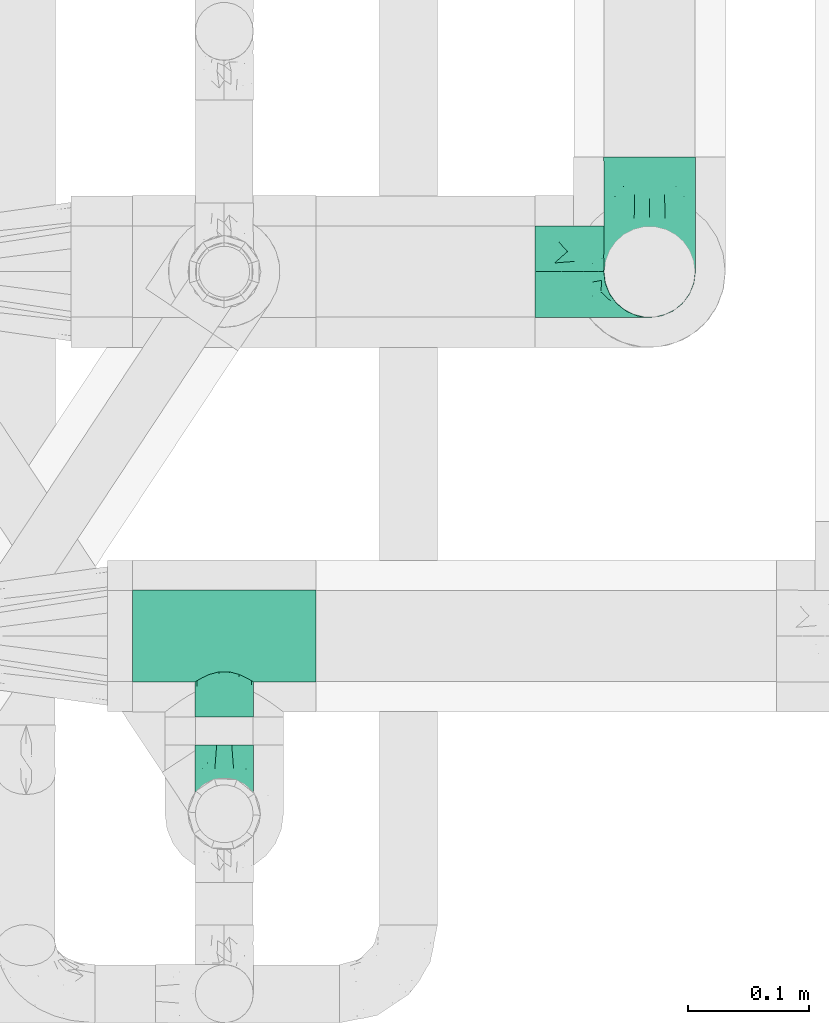
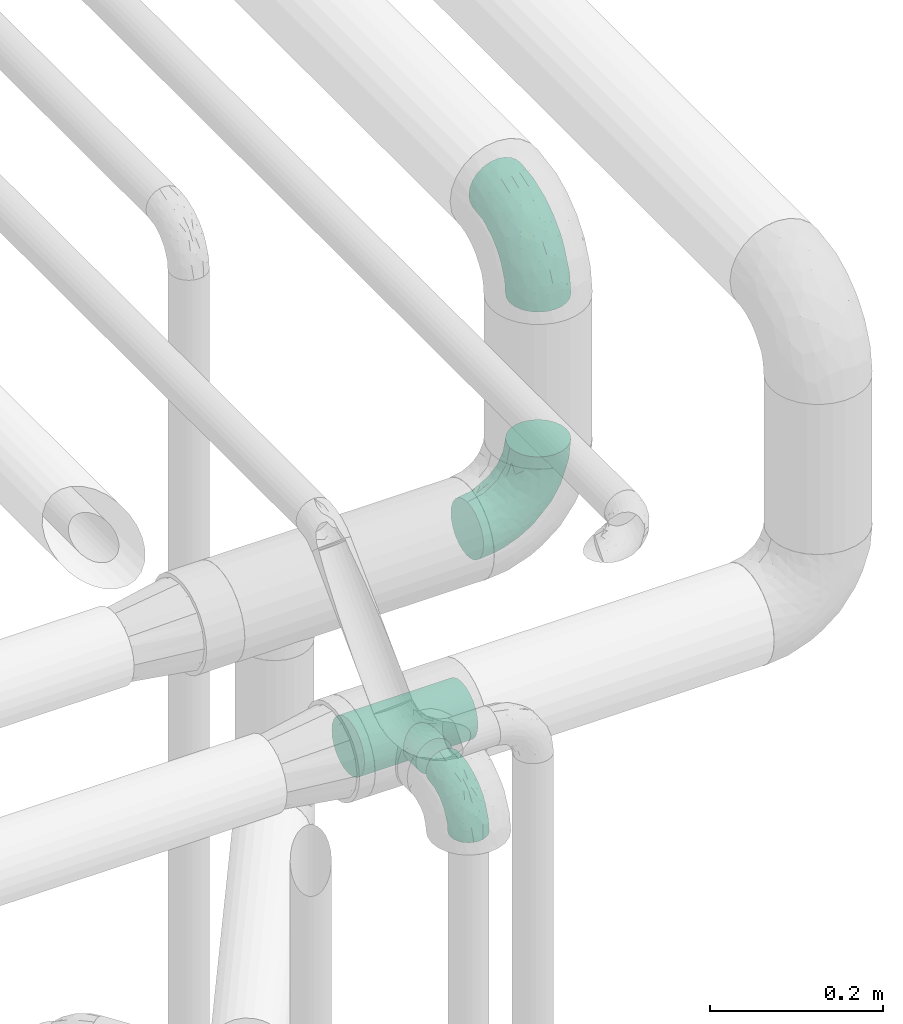
# One storey, part 664 of 827: 4 flow fittings.
"""IFC2X3 building model written with IfcOpenShell, lengths in millimetres."""

from ifc_helpers import new_model, entity, si_unit, converted_unit, derived_unit, direction, frame, origin, place, context, subcontext, project, spatial, faceted_brep, source, transform, mapped, material, type_object, type_shapes, element, save


model = new_model("IFC2X3")

# Units and contexts
model_context = context("Model", 3, precision=0.01, world=origin(), true_north=direction((6.12303176911189e-17, 1.0)))
body_context = subcontext(model_context, "Body", "Model", "MODEL_VIEW")
ifc_project = project(units=[si_unit("LENGTHUNIT", "METRE", prefix="MILLI"), si_unit("AREAUNIT", "SQUARE_METRE"), si_unit("VOLUMEUNIT", "CUBIC_METRE"), converted_unit("PLANEANGLEUNIT", "DEGREE", entity("IfcRatioMeasure", 0.0174532925199433), si_unit("PLANEANGLEUNIT", "RADIAN"), dimensions=[0, 0, 0, 0, 0, 0, 0]), si_unit("MASSUNIT", "GRAM", prefix="KILO"), derived_unit("MASSDENSITYUNIT", [(si_unit("MASSUNIT", "GRAM", prefix="KILO"), 1), (si_unit("LENGTHUNIT", "METRE"), -3)]), derived_unit("MOMENTOFINERTIAUNIT", [(si_unit("LENGTHUNIT", "METRE"), 4)]), si_unit("TIMEUNIT", "SECOND"), si_unit("FREQUENCYUNIT", "HERTZ"), si_unit("THERMODYNAMICTEMPERATUREUNIT", "DEGREE_CELSIUS"), derived_unit("THERMALTRANSMITTANCEUNIT", [(si_unit("MASSUNIT", "GRAM", prefix="KILO"), 1), (si_unit("THERMODYNAMICTEMPERATUREUNIT", "KELVIN"), -1), (si_unit("TIMEUNIT", "SECOND"), -3)]), derived_unit("VOLUMETRICFLOWRATEUNIT", [(si_unit("LENGTHUNIT", "METRE"), 3), (si_unit("TIMEUNIT", "SECOND"), -1)]), derived_unit("MASSFLOWRATEUNIT", [(si_unit("MASSUNIT", "GRAM", prefix="KILO"), 1), (si_unit("TIMEUNIT", "SECOND"), -1)]), derived_unit("ROTATIONALFREQUENCYUNIT", [(si_unit("TIMEUNIT", "SECOND"), -1)]), si_unit("ELECTRICCURRENTUNIT", "AMPERE"), si_unit("ELECTRICVOLTAGEUNIT", "VOLT"), si_unit("POWERUNIT", "WATT"), si_unit("FORCEUNIT", "NEWTON", prefix="KILO"), si_unit("ILLUMINANCEUNIT", "LUX"), si_unit("LUMINOUSFLUXUNIT", "LUMEN"), si_unit("LUMINOUSINTENSITYUNIT", "CANDELA"), derived_unit("USERDEFINED", [(si_unit("MASSUNIT", "GRAM", prefix="KILO"), -1), (si_unit("LENGTHUNIT", "METRE"), -2), (si_unit("TIMEUNIT", "SECOND"), 3), (si_unit("LUMINOUSFLUXUNIT", "LUMEN"), 1)]), derived_unit("LINEARVELOCITYUNIT", [(si_unit("LENGTHUNIT", "METRE"), 1), (si_unit("TIMEUNIT", "SECOND"), -1)]), si_unit("PRESSUREUNIT", "PASCAL"), derived_unit("USERDEFINED", [(si_unit("LENGTHUNIT", "METRE"), -2), (si_unit("MASSUNIT", "GRAM", prefix="KILO"), 1), (si_unit("TIMEUNIT", "SECOND"), -2)]), derived_unit("LINEARFORCEUNIT", [(si_unit("MASSUNIT", "GRAM", prefix="KILO"), 1), (si_unit("LENGTHUNIT", "METRE"), 1), (si_unit("TIMEUNIT", "SECOND"), -2), (si_unit("LENGTHUNIT", "METRE"), -1)]), derived_unit("PLANARFORCEUNIT", [(si_unit("MASSUNIT", "GRAM", prefix="KILO"), 1), (si_unit("LENGTHUNIT", "METRE"), 1), (si_unit("TIMEUNIT", "SECOND"), -2), (si_unit("LENGTHUNIT", "METRE"), -2)])], contexts=[model_context])

# Site, building, storey
site_placement = place(None, origin())
site = spatial("IfcSite", under=ifc_project, at=site_placement, CompositionType="ELEMENT")
building_placement = place(site_placement, origin())
building = spatial("IfcBuilding", under=site, at=building_placement, CompositionType="ELEMENT")
storey_placement = place(building_placement, frame((0.0, 0.0, 28200.0)))
storey = spatial("IfcBuildingStorey", under=building, at=storey_placement, Name="08", CompositionType="ELEMENT", Elevation=28200.0)

# Flow fittings
ifc_material = material()
pipe_fitting_type_1 = type_object("IfcPipeFittingType", Name="ADSK_1", PredefinedType="NOTDEFINED", material=ifc_material)
shared_shape_1 = source(origin(), body_context, "Body", "Brep", [
    faceted_brep([(-76.0, 9.85, -36.75), (-76.0, 0.0, -38.05), (-76.0, -9.85, -36.75), (-76.0, -19.03, -32.95), (-76.0, -26.91, -26.91), (-76.0, -32.95, -19.03), (-76.0, -36.75, -9.85), (-76.0, -38.05, 0.0), (-76.0, -36.75, 9.85), (-76.0, -32.95, 19.02), (-76.0, -26.91, 26.91), (-76.0, -19.03, 32.95), (-76.0, -9.85, 36.75), (-76.0, 0.0, 38.05), (-76.0, 9.85, 36.75), (-76.0, 19.02, 32.95), (-76.0, 26.91, 26.91), (-76.0, 32.95, 19.02), (-76.0, 36.75, 9.85), (-76.0, 38.05, 0.0), (-76.0, 36.75, -9.85), (-76.0, 32.95, -19.03), (-76.0, 26.91, -26.91), (-76.0, 19.02, -32.95), (76.0, 26.91, -26.91), (76.0, 32.95, -19.03), (76.0, 36.75, -9.85), (76.0, 38.05, 0.0), (76.0, 36.75, 9.85), (76.0, 32.95, 19.02), (76.0, 26.91, 26.91), (76.0, 19.02, 32.95), (76.0, 9.85, 36.75), (76.0, 0.0, 38.05), (76.0, -9.85, 36.75), (76.0, -19.03, 32.95), (76.0, -26.91, 26.91), (76.0, -32.95, 19.02), (76.0, -36.75, 9.85), (76.0, -38.05, 0.0), (76.0, -36.75, -9.85), (76.0, -32.95, -19.03), (76.0, -26.91, -26.91), (76.0, -19.03, -32.95), (76.0, -9.85, -36.75), (76.0, 0.0, -38.05), (76.0, 9.85, -36.75), (76.0, 19.02, -32.95), (22.62, -37.1, 8.45), (23.39, -37.58, 4.22), (24.15, -38.05, 0.0), (18.42, -34.7, 15.61), (4.31, -29.72, 23.76), (12.18, -31.83, 20.86), (8.24, -30.77, 22.31), (-24.15, -38.05, 0.0), (-23.39, -37.58, 4.22), (-22.63, -37.1, 8.44), (-18.43, -34.7, 15.61), (-12.18, -31.83, 20.85), (-4.31, -29.72, 23.76), (0.0, -29.72, 23.76), (4.31, -29.72, -23.76), (12.18, -31.83, -20.86), (8.24, -30.77, -22.31), (18.42, -34.7, -15.61), (22.62, -37.1, -8.45), (23.39, -37.58, -4.22), (-4.31, -29.72, -23.76), (-12.18, -31.83, -20.85), (-18.43, -34.7, -15.61), (0.0, -29.72, -23.76), (-22.63, -37.1, -8.44), (-23.39, -37.58, -4.22), (0.0, -67.0, -24.15), (6.25, -67.0, -23.33), (12.08, -67.0, -20.91), (17.08, -67.0, -17.08), (20.91, -67.0, -12.08), (23.33, -67.0, -6.25), (24.15, -67.0, 0.0), (23.33, -67.0, 6.25), (20.91, -67.0, 12.07), (17.08, -67.0, 17.08), (12.08, -67.0, 20.91), (6.25, -67.0, 23.33), (0.0, -67.0, 24.15), (-6.25, -67.0, 23.33), (-12.07, -67.0, 20.91), (-17.08, -67.0, 17.08), (-20.91, -67.0, 12.07), (-23.33, -67.0, 6.25), (-24.15, -67.0, 0.0), (-23.33, -67.0, -6.25), (-20.91, -67.0, -12.08), (-17.08, -67.0, -17.08), (-12.07, -67.0, -20.91), (-6.25, -67.0, -23.33)], [[[0, 1, 2, 3, 4, 5, 6, 7, 8, 9, 10, 11, 12, 13, 14, 15, 16, 17, 18, 19, 20, 21, 22, 23]], [[24, 25, 26, 27, 28, 29, 30, 31, 32, 33, 34, 35, 36, 37, 38, 39, 40, 41, 42, 43, 44, 45, 46, 47]], [[39, 38, 48]], [[39, 48, 49, 50]], [[38, 51, 48]], [[37, 36, 52]], [[53, 51, 37]], [[37, 52, 54, 53]], [[36, 10, 52]], [[37, 51, 38]], [[7, 55, 56, 57]], [[8, 7, 57]], [[57, 58, 8]], [[59, 60, 9]], [[59, 9, 58]], [[9, 60, 10]], [[58, 9, 8]], [[10, 60, 61, 52]], [[36, 35, 11, 10]], [[13, 12, 34, 33]], [[12, 11, 35, 34]], [[14, 13, 33, 32]], [[29, 28, 18, 17]], [[16, 15, 31, 30]], [[17, 16, 30, 29]], [[32, 31, 15, 14]], [[19, 18, 28, 27]], [[26, 25, 21, 20]], [[25, 24, 22, 21]], [[27, 26, 20, 19]], [[45, 44, 2, 1]], [[0, 23, 47, 46]], [[1, 0, 46, 45]], [[24, 47, 23, 22]], [[3, 2, 44, 43]], [[43, 42, 4, 3]], [[42, 41, 62]], [[41, 63, 64, 62]], [[41, 65, 63]], [[42, 62, 4]], [[40, 39, 66]], [[66, 65, 40]], [[39, 50, 67, 66]], [[40, 65, 41]], [[68, 69, 5]], [[5, 4, 68]], [[69, 70, 5]], [[4, 62, 71, 68]], [[70, 72, 6]], [[72, 7, 6]], [[7, 72, 73, 55]], [[70, 6, 5]], [[74, 75, 76, 77, 78, 79, 80, 81, 82, 83, 84, 85, 86, 87, 88, 89, 90, 91, 92, 93, 94, 95, 96, 97]], [[56, 92, 91]], [[86, 60, 87]], [[59, 89, 88]], [[84, 54, 85]], [[49, 80, 50]], [[59, 88, 87]], [[49, 48, 81]], [[91, 57, 56]], [[55, 92, 56]], [[57, 91, 90]], [[57, 90, 58]], [[89, 58, 90]], [[89, 59, 58]], [[87, 60, 59]], [[86, 52, 61, 60]], [[84, 53, 54]], [[83, 53, 84]], [[48, 82, 81]], [[83, 82, 51]], [[52, 86, 85]], [[54, 52, 85]], [[53, 83, 51]], [[51, 82, 48]], [[80, 49, 81]], [[79, 67, 80]], [[77, 65, 78]], [[64, 76, 75]], [[79, 66, 67]], [[78, 66, 79]], [[63, 77, 76]], [[67, 50, 80]], [[66, 78, 65]], [[75, 62, 64]], [[63, 65, 77]], [[74, 68, 71, 62]], [[74, 62, 75]], [[73, 92, 55]], [[69, 97, 96]], [[73, 72, 93]], [[95, 69, 96]], [[72, 94, 93]], [[95, 94, 70]], [[68, 74, 97]], [[97, 69, 68]], [[69, 95, 70]], [[70, 94, 72]], [[92, 73, 93]], [[64, 63, 76]]]),
])
type_shapes(pipe_fitting_type_1, [shared_shape_1])
flow_fitting_1_placement = place(storey_placement, frame((48292.02, 13933.51, 2597.5)))
element("IfcFlowFitting", 1, at=flow_fitting_1_placement, inside=storey, type_object=pipe_fitting_type_1, material=ifc_material, Name="ADSK_1", ObjectType="ADSK_1", context=body_context, shape_type="MappedRepresentation", body=[
    mapped(shared_shape_1, transform((0.0, 0.0, 0.0), scale=1.0)),
])
pipe_fitting_type_2 = type_object("IfcPipeFittingType", Name="ADSK_1", PredefinedType="NOTDEFINED", material=ifc_material)
shared_shape_2 = source(origin(), body_context, "Body", "Brep", [
    faceted_brep([(-57.0, 12.07, -20.91), (-57.0, 6.25, -23.33), (-57.0, 0.0, -24.15), (-57.0, -6.25, -23.33), (-57.0, -12.08, -20.91), (-57.0, -17.08, -17.08), (-57.0, -20.91, -12.08), (-57.0, -23.33, -6.25), (-57.0, -24.15, 0.0), (-57.0, -23.33, 6.25), (-57.0, -20.91, 12.07), (-57.0, -17.08, 17.08), (-57.0, -12.08, 20.91), (-57.0, -6.25, 23.33), (-57.0, 0.0, 24.15), (-57.0, 6.25, 23.33), (-57.0, 12.07, 20.91), (-57.0, 17.08, 17.08), (-57.0, 20.91, 12.07), (-57.0, 23.33, 6.25), (-57.0, 24.15, 0.0), (-57.0, 23.33, -6.25), (-57.0, 20.91, -12.08), (-57.0, 17.08, -17.08), (0.0, 57.0, -24.15), (-6.25, 57.0, -23.33), (-12.07, 57.0, -20.91), (-17.08, 57.0, -17.08), (-20.91, 57.0, -12.08), (-23.33, 57.0, -6.25), (-24.15, 57.0, 0.0), (-23.33, 57.0, 6.25), (-20.91, 57.0, 12.07), (-17.08, 57.0, 17.08), (-12.07, 57.0, 20.91), (-6.25, 57.0, 23.33), (0.0, 57.0, 24.15), (6.25, 57.0, 23.33), (12.08, 57.0, 20.91), (17.08, 57.0, 17.08), (20.91, 57.0, 12.07), (23.33, 57.0, 6.25), (24.15, 57.0, 0.0), (23.33, 57.0, -6.25), (20.91, 57.0, -12.08), (17.08, 57.0, -17.08), (12.08, 57.0, -20.91), (6.25, 57.0, -23.33), (14.9, 21.14, 6.17), (13.61, 24.64, 12.48), (6.23, 8.95, 8.98), (-41.47, -21.06, 0.0), (-41.92, -18.38, 13.72), (-24.64, -13.61, 12.48), (-37.37, -13.24, 18.15), (-6.8, -4.93, 8.18), (-21.76, -15.19, 6.22), (-12.78, -9.18, 0.0), (-37.73, -20.51, 7.75), (-7.38, 7.38, 20.24), (-23.37, -4.26, 20.42), (-11.9, -3.19, 15.86), (-42.14, -8.7, 21.82), (13.24, 37.37, 18.15), (9.33, 23.53, 16.85), (4.26, 23.37, 20.42), (2.77, 10.92, 15.55), (-29.46, 0.91, 23.52), (-44.13, 20.56, 15.69), (-39.25, 26.33, 10.88), (-49.02, 22.92, 9.96), (-34.58, 23.87, 17.15), (-15.8, 6.8, 22.81), (-8.67, 20.47, 23.88), (-18.12, 12.9, 24.08), (-48.29, 14.92, 19.65), (-44.06, -2.85, 23.78), (-9.23, 48.95, 22.58), (-3.78, 42.74, 24.07), (-40.34, 4.26, 24.09), (-44.02, 26.14, 5.46), (-44.04, 9.88, 22.74), (-4.95, 16.87, 22.52), (-2.75, 1.43, 12.5), (-25.48, 40.98, 10.71), (20.51, 37.73, 7.75), (18.38, 41.92, 13.72), (8.7, 42.14, 21.82), (-25.95, -17.97, 0.0), (2.85, 44.06, 23.78), (21.06, 41.47, 0.0), (17.97, 25.95, 0.0), (-24.04, -9.27, 17.13), (-33.26, 33.26, 5.86), (-28.55, 40.57, 0.0), (-40.57, 28.55, 0.0), (-25.29, 47.19, 4.06), (-27.01, 31.1, 16.77), (-15.7, 43.95, 19.9), (-20.27, 45.22, 15.61), (-30.53, 31.98, 12.64), (-11.28, 38.33, 22.92), (-9.97, 27.88, 24.09), (-20.15, 30.26, 21.25), (-31.25, 11.75, 23.64), (-28.75, 7.23, 24.15), (-29.53, 18.06, 22.27), (-28.44, 24.21, 20.02), (-37.55, 17.7, 20.26), (-15.88, 29.25, 22.99), (-20.82, 20.82, 23.44), (-0.91, 29.46, 23.52), (-13.5, -7.67, 12.04), (1.49, 1.56, 5.16), (8.86, 10.35, 4.59), (0.38, -0.38, 0.0), (9.18, 12.78, 0.0), (-37.37, -13.24, -18.15), (8.86, 10.35, -4.59), (-45.22, 20.27, -15.61), (-43.95, 15.7, -19.9), (-38.33, 11.28, -22.92), (-48.95, 9.23, -22.58), (-47.19, 25.29, -4.06), (-33.26, 33.26, -5.86), (18.38, 41.92, -13.72), (-30.26, 20.15, -21.25), (2.85, 44.06, -23.78), (-4.26, 40.34, -24.09), (-40.98, 25.48, -10.71), (-41.92, -18.38, -13.72), (9.25, 23.5, -16.92), (4.26, 23.37, -20.42), (13.24, 37.37, -18.15), (-37.73, -20.51, -7.75), (-11.75, 31.25, -23.64), (-7.23, 28.75, -24.15), (-12.9, 18.12, -24.08), (8.7, 42.14, -21.82), (-44.06, -2.85, -23.78), (-6.8, 15.8, -22.81), (-20.47, 8.67, -23.88), (-24.64, -13.61, -12.48), (-42.74, 3.78, -24.07), (-18.06, 29.53, -22.27), (-24.21, 28.44, -20.02), (-27.88, 9.97, -24.09), (-31.1, 27.01, -16.77), (-26.14, 44.02, -5.46), (14.9, 21.14, -6.17), (20.51, 37.73, -7.75), (-9.88, 44.04, -22.74), (-20.56, 44.13, -15.69), (-21.76, -15.19, -6.22), (-13.5, -7.67, -12.04), (-24.14, -9.76, -16.74), (-11.9, -3.19, -15.86), (-14.92, 48.29, -19.65), (-23.37, -4.26, -20.42), (-0.91, 29.46, -23.52), (-26.33, 39.25, -10.88), (-23.87, 34.58, -17.15), (-42.14, -8.7, -21.82), (-22.92, 49.02, -9.96), (13.61, 24.64, -12.48), (-31.98, 30.53, -12.64), (-16.87, 4.95, -22.52), (-17.7, 37.55, -20.26), (-29.25, 15.88, -22.99), (-20.82, 20.82, -23.44), (-29.46, 0.91, -23.52), (-7.38, 7.38, -20.24), (2.77, 10.92, -15.55), (6.23, 8.95, -8.98), (-6.8, -4.93, -8.18), (-2.81, 1.41, -12.54), (1.49, 1.56, -5.16)], [[[0, 1, 2, 3, 4, 5, 6, 7, 8, 9, 10, 11, 12, 13, 14, 15, 16, 17, 18, 19, 20, 21, 22, 23]], [[24, 25, 26, 27, 28, 29, 30, 31, 32, 33, 34, 35, 36, 37, 38, 39, 40, 41, 42, 43, 44, 45, 46, 47]], [[48, 49, 50]], [[9, 8, 51]], [[52, 53, 54]], [[55, 56, 57]], [[10, 58, 52]], [[9, 58, 10]], [[59, 60, 61]], [[54, 12, 11]], [[54, 62, 12]], [[63, 39, 38]], [[64, 65, 66]], [[62, 60, 67]], [[68, 69, 70]], [[71, 69, 68]], [[72, 73, 74]], [[16, 75, 17]], [[13, 76, 14]], [[35, 77, 78]], [[14, 79, 15]], [[17, 68, 18]], [[14, 76, 79]], [[20, 19, 80]], [[70, 19, 18]], [[81, 15, 79]], [[15, 81, 16]], [[73, 72, 82]], [[66, 83, 50]], [[32, 31, 84]], [[85, 86, 49]], [[63, 87, 65]], [[56, 58, 88]], [[36, 89, 37]], [[85, 41, 40]], [[36, 35, 78]], [[90, 41, 85]], [[40, 39, 86]], [[12, 62, 13]], [[86, 85, 40]], [[48, 85, 49]], [[85, 91, 90]], [[87, 38, 37]], [[92, 60, 54]], [[80, 69, 93]], [[93, 94, 95]], [[10, 52, 11]], [[94, 96, 30]], [[97, 98, 99]], [[80, 93, 95]], [[100, 97, 84]], [[99, 98, 33]], [[101, 102, 78]], [[103, 101, 98]], [[96, 31, 30]], [[77, 98, 101]], [[77, 35, 34]], [[34, 33, 98]], [[9, 51, 58]], [[87, 63, 38]], [[104, 105, 74]], [[106, 103, 107]], [[106, 81, 104]], [[75, 68, 17]], [[108, 107, 71]], [[33, 32, 99]], [[109, 103, 110]], [[101, 109, 102]], [[89, 78, 111]], [[53, 52, 58]], [[54, 11, 52]], [[60, 62, 54]], [[88, 58, 51]], [[76, 62, 67]], [[53, 112, 92]], [[60, 59, 72]], [[39, 63, 86]], [[49, 86, 63]], [[89, 87, 37]], [[42, 41, 90]], [[111, 82, 65]], [[111, 65, 87]], [[65, 59, 66]], [[104, 81, 79]], [[75, 81, 108]], [[32, 84, 99]], [[97, 99, 84]], [[98, 97, 103]], [[106, 107, 108]], [[74, 102, 110]], [[111, 78, 102]], [[74, 110, 104]], [[74, 67, 72]], [[61, 92, 112]], [[66, 59, 61]], [[56, 53, 58]], [[66, 50, 49]], [[61, 112, 83]], [[66, 49, 64]], [[78, 89, 36]], [[87, 89, 111]], [[62, 76, 13]], [[79, 76, 67]], [[100, 93, 69]], [[96, 93, 84]], [[55, 113, 50]], [[113, 114, 50]], [[104, 79, 105]], [[106, 104, 110]], [[20, 80, 95]], [[85, 48, 91]], [[115, 114, 113]], [[116, 91, 48]], [[70, 80, 19]], [[93, 96, 94]], [[84, 31, 96]], [[103, 106, 110]], [[81, 106, 108]], [[103, 97, 107]], [[71, 107, 97]], [[71, 97, 100]], [[108, 71, 68]], [[79, 67, 105]], [[67, 74, 105]], [[115, 113, 57]], [[112, 56, 55]], [[56, 88, 57]], [[60, 72, 67]], [[82, 72, 59]], [[65, 82, 59]], [[82, 111, 73]], [[111, 102, 73]], [[102, 74, 73]], [[81, 75, 16]], [[68, 75, 108]], [[68, 70, 18]], [[80, 70, 69]], [[98, 77, 34]], [[78, 77, 101]], [[93, 100, 84]], [[71, 100, 69]], [[102, 109, 110]], [[101, 103, 109]], [[53, 92, 54]], [[61, 60, 92]], [[56, 112, 53]], [[83, 112, 55]], [[50, 83, 55]], [[61, 83, 66]], [[49, 63, 64]], [[65, 64, 63]], [[57, 113, 55]], [[114, 115, 116]], [[116, 48, 114]], [[48, 50, 114]], [[117, 5, 4]], [[116, 115, 118]], [[119, 120, 23]], [[121, 122, 120]], [[95, 123, 20]], [[0, 23, 120]], [[124, 95, 94]], [[125, 45, 44]], [[121, 120, 126]], [[24, 127, 128]], [[22, 21, 129]], [[0, 122, 1]], [[5, 117, 130]], [[131, 132, 133]], [[134, 88, 51]], [[135, 136, 137]], [[6, 5, 130]], [[46, 138, 47]], [[139, 3, 2]], [[140, 141, 137]], [[6, 134, 7]], [[134, 130, 142]], [[143, 2, 1]], [[144, 126, 145]], [[121, 146, 143]], [[147, 120, 119]], [[94, 148, 124]], [[149, 150, 91]], [[30, 29, 148]], [[151, 25, 128]], [[27, 152, 28]], [[134, 153, 88]], [[154, 155, 156]], [[27, 26, 157]], [[151, 26, 25]], [[155, 158, 156]], [[24, 47, 127]], [[1, 122, 143]], [[138, 132, 159]], [[160, 152, 161]], [[24, 128, 25]], [[46, 133, 138]], [[162, 117, 4]], [[148, 160, 124]], [[152, 160, 163]], [[154, 142, 155]], [[45, 125, 133]], [[133, 46, 45]], [[125, 164, 133]], [[51, 7, 134]], [[42, 90, 43]], [[165, 147, 129]], [[153, 134, 142]], [[43, 150, 44]], [[162, 4, 3]], [[141, 140, 166]], [[117, 162, 158]], [[163, 29, 28]], [[43, 90, 150]], [[123, 21, 20]], [[144, 151, 135]], [[157, 152, 27]], [[167, 145, 161]], [[23, 22, 119]], [[168, 126, 169]], [[121, 168, 146]], [[139, 143, 170]], [[142, 130, 117]], [[8, 7, 51]], [[134, 6, 130]], [[139, 162, 3]], [[170, 166, 158]], [[170, 158, 162]], [[158, 171, 156]], [[44, 150, 125]], [[91, 150, 90]], [[164, 125, 150]], [[132, 138, 133]], [[127, 138, 159]], [[131, 164, 172]], [[132, 171, 140]], [[135, 151, 128]], [[157, 151, 167]], [[22, 129, 119]], [[147, 119, 129]], [[120, 147, 126]], [[144, 145, 167]], [[137, 146, 169]], [[170, 143, 146]], [[137, 169, 135]], [[137, 159, 140]], [[171, 172, 156]], [[173, 174, 175]], [[156, 175, 154]], [[174, 57, 153]], [[132, 172, 171]], [[172, 164, 173]], [[143, 139, 2]], [[162, 139, 170]], [[138, 127, 47]], [[128, 127, 159]], [[165, 124, 160]], [[123, 124, 129]], [[149, 173, 164]], [[176, 174, 173]], [[135, 128, 136]], [[144, 135, 169]], [[150, 149, 164]], [[176, 118, 115]], [[149, 91, 116]], [[30, 148, 94]], [[163, 148, 29]], [[124, 123, 95]], [[129, 21, 123]], [[126, 144, 169]], [[151, 144, 167]], [[126, 147, 145]], [[161, 145, 147]], [[161, 147, 165]], [[167, 161, 152]], [[128, 159, 136]], [[159, 137, 136]], [[154, 153, 142]], [[132, 140, 159]], [[174, 176, 57]], [[57, 88, 153]], [[166, 140, 171]], [[158, 166, 171]], [[166, 170, 141]], [[170, 146, 141]], [[146, 137, 141]], [[151, 157, 26]], [[152, 157, 167]], [[152, 163, 28]], [[148, 163, 160]], [[120, 122, 0]], [[143, 122, 121]], [[124, 165, 129]], [[161, 165, 160]], [[146, 168, 169]], [[121, 126, 168]], [[142, 117, 155]], [[158, 155, 117]], [[175, 156, 172]], [[153, 154, 174]], [[173, 175, 172]], [[174, 154, 175]], [[164, 131, 133]], [[172, 132, 131]], [[176, 173, 118]], [[57, 176, 115]], [[173, 149, 118]], [[149, 116, 118]]]),
])
type_shapes(pipe_fitting_type_2, [shared_shape_2])
flow_fitting_2_placement = place(storey_placement, frame((48292.02, 13786.1, 2597.5), z_axis=(-1.0, 0.0, 0.0), x_axis=(0.0, 0.0, 1.0)))
element("IfcFlowFitting", 2, at=flow_fitting_2_placement, inside=storey, type_object=pipe_fitting_type_2, material=ifc_material, Name="ADSK_1", ObjectType="ADSK_1", context=body_context, shape_type="MappedRepresentation", body=[
    mapped(shared_shape_2, transform((0.0, 0.0, 0.0), scale=1.0)),
])
pipe_fitting_type_3 = type_object("IfcPipeFittingType", Name="ADSK_1", PredefinedType="NOTDEFINED", material=ifc_material)
shared_shape_3 = source(origin(), body_context, "Body", "Brep", [
    faceted_brep([(-95.0, 19.02, -32.95), (-95.0, 9.85, -36.75), (-95.0, 0.0, -38.05), (-95.0, -9.85, -36.75), (-95.0, -19.03, -32.95), (-95.0, -26.91, -26.91), (-95.0, -32.95, -19.03), (-95.0, -36.75, -9.85), (-95.0, -38.05, 0.0), (-95.0, -36.75, 9.85), (-95.0, -32.95, 19.02), (-95.0, -26.91, 26.91), (-95.0, -19.03, 32.95), (-95.0, -9.85, 36.75), (-95.0, 0.0, 38.05), (-95.0, 9.85, 36.75), (-95.0, 19.02, 32.95), (-95.0, 26.91, 26.91), (-95.0, 32.95, 19.02), (-95.0, 36.75, 9.85), (-95.0, 38.05, 0.0), (-95.0, 36.75, -9.85), (-95.0, 32.95, -19.03), (-95.0, 26.91, -26.91), (0.0, 95.0, -38.05), (-9.85, 95.0, -36.75), (-19.02, 95.0, -32.95), (-26.91, 95.0, -26.91), (-32.95, 95.0, -19.03), (-36.75, 95.0, -9.85), (-38.05, 95.0, 0.0), (-36.75, 95.0, 9.85), (-32.95, 95.0, 19.02), (-26.91, 95.0, 26.91), (-19.02, 95.0, 32.95), (-9.85, 95.0, 36.75), (0.0, 95.0, 38.05), (9.85, 95.0, 36.75), (19.03, 95.0, 32.95), (26.91, 95.0, 26.91), (32.95, 95.0, 19.02), (36.75, 95.0, 9.85), (38.05, 95.0, 0.0), (36.75, 95.0, -9.85), (32.95, 95.0, -19.03), (26.91, 95.0, -26.91), (19.03, 95.0, -32.95), (9.85, 95.0, -36.75), (-7.99, -4.96, 6.3), (-0.92, 0.92, 0.0), (4.62, 8.1, 8.01), (-76.19, -35.57, 0.0), (-64.32, -32.32, 12.43), (20.51, 62.45, 28.68), (-60.56, -33.52, 0.0), (-70.4, -13.47, 34.42), (-39.61, -5.88, 32.32), (-49.6, 2.07, 37.1), (-70.34, -28.81, 21.71), (14.64, 40.81, 26.5), (5.88, 39.61, 32.32), (3.59, 20.77, 25.31), (-40.45, 68.06, 16.75), (-62.45, -20.51, 28.68), (-44.52, -26.87, 0.0), (-28.47, -20.22, 0.0), (-26.43, -17.83, 8.75), (-76.1, 39.63, 10.76), (-72.74, 37.58, 18.19), (-60.35, 46.18, 14.61), (-13.4, 13.4, 32.12), (-20.77, -3.59, 25.31), (-14.66, 81.47, 35.56), (-6.22, 71.26, 37.92), (-57.5, 42.48, 22.79), (-15.0, 34.74, 37.7), (-27.1, 12.08, 36.05), (-9.2, 28.81, 35.63), (-79.98, 23.7, 30.95), (-73.68, -4.3, 37.48), (-30.74, 21.67, 37.97), (-62.36, 47.59, 6.79), (-72.71, 32.83, 24.69), (-67.42, 7.02, 37.95), (-32.13, 75.27, 24.51), (-43.46, 51.47, 26.26), (-24.98, 73.15, 31.29), (20.59, 41.28, 19.85), (7.79, 16.09, 15.86), (-73.21, 42.39, 0.0), (-54.73, 54.73, 0.0), (-73.44, 15.79, 35.79), (-5.94, 4.32, 20.43), (28.81, 70.34, 21.71), (32.32, 64.32, 12.43), (-53.59, 26.2, 35.09), (-52.02, 19.31, 37.21), (21.38, 33.53, 10.34), (26.87, 44.52, 0.0), (-48.28, 12.14, 38.05), (4.3, 73.68, 37.48), (-44.08, -25.52, 12.79), (-41.28, -20.59, 19.85), (35.57, 76.19, 0.0), (-47.26, 54.3, 20.18), (-47.4, 61.99, 8.58), (-42.39, 73.21, 0.0), (-39.67, 78.86, 7.21), (-45.69, 36.84, 33.11), (-32.83, 50.13, 33.35), (13.47, 70.4, 34.42), (-18.25, 63.73, 36.07), (-40.63, -13.75, 27.22), (-16.63, 46.37, 37.95), (-53.47, 38.79, 28.59), (-26.07, 48.54, 36.15), (-34.51, 34.51, 36.86), (-2.07, 49.6, 37.1), (-22.79, -10.49, 19.23), (-61.73, 28.67, 31.87), (9.65, 14.7, 0.0), (20.22, 28.47, 0.0), (33.52, 60.56, 0.0), (-11.42, -5.44, 13.25), (-14.7, -9.65, 0.0), (-81.47, 14.66, -35.56), (-62.45, -20.51, -28.68), (-71.26, 6.22, -37.92), (-75.27, 32.13, -24.51), (-73.15, 24.98, -31.29), (13.47, 70.4, -34.42), (5.88, 39.61, -32.32), (-2.07, 49.6, -37.1), (-78.86, 39.67, -7.21), (-70.4, -13.47, -34.42), (-39.61, -5.88, -32.32), (-61.99, 47.4, -8.58), (32.32, 64.32, -12.43), (28.81, 70.34, -21.71), (-63.73, 18.25, -36.07), (-50.13, 32.83, -33.35), (4.3, 73.68, -37.48), (-7.02, 67.42, -37.95), (-39.63, 76.1, -10.76), (-46.18, 60.35, -14.61), (-47.59, 62.36, -6.79), (-64.32, -32.32, -12.43), (-26.2, 53.59, -35.09), (-15.79, 73.44, -35.79), (-19.31, 52.02, -37.21), (-37.58, 72.74, -18.19), (-70.34, -28.81, -21.71), (-42.48, 57.5, -22.79), (-38.79, 53.47, -28.59), (-51.47, 43.46, -26.26), (-32.83, 72.71, -24.69), (-46.37, 16.63, -37.95), (-73.68, -4.3, -37.48), (-41.28, -20.59, -19.85), (-44.08, -25.52, -12.79), (13.75, 40.63, -27.22), (20.51, 62.45, -28.68), (-68.06, 40.45, -16.75), (-54.3, 47.26, -20.18), (-12.14, 48.28, -38.05), (-21.67, 30.74, -37.97), (-36.84, 45.69, -33.11), (-11.42, -5.44, -13.25), (7.79, 16.09, -15.86), (4.62, 8.1, -8.01), (-23.7, 79.98, -30.95), (-26.43, -17.83, -8.75), (-7.99, -4.96, -6.3), (-40.81, -14.64, -26.5), (-20.77, -3.59, -25.31), (-34.74, 15.0, -37.7), (-12.08, 27.1, -36.05), (-28.81, 9.2, -35.63), (-22.79, -10.49, -19.23), (21.38, 33.53, -10.34), (20.59, 41.28, -19.85), (-48.54, 26.07, -36.15), (-49.6, 2.07, -37.1), (-13.4, 13.4, -32.12), (3.59, 20.77, -25.31), (-28.67, 61.73, -31.87), (-34.51, 34.51, -36.86), (-5.94, 4.32, -20.43)], [[[0, 1, 2, 3, 4, 5, 6, 7, 8, 9, 10, 11, 12, 13, 14, 15, 16, 17, 18, 19, 20, 21, 22, 23]], [[24, 25, 26, 27, 28, 29, 30, 31, 32, 33, 34, 35, 36, 37, 38, 39, 40, 41, 42, 43, 44, 45, 46, 47]], [[48, 49, 50]], [[51, 52, 9]], [[53, 39, 38]], [[9, 52, 10]], [[54, 52, 51]], [[55, 56, 57]], [[11, 10, 58]], [[59, 60, 61]], [[32, 31, 62]], [[63, 12, 11]], [[63, 55, 12]], [[64, 65, 66]], [[67, 68, 69]], [[70, 56, 71]], [[35, 72, 73]], [[69, 68, 74]], [[75, 76, 77]], [[16, 78, 17]], [[13, 79, 14]], [[76, 75, 80]], [[67, 69, 81]], [[18, 17, 82]], [[14, 79, 83]], [[20, 19, 67]], [[84, 85, 86]], [[87, 61, 88]], [[89, 81, 90]], [[18, 82, 68]], [[15, 91, 16]], [[14, 83, 15]], [[71, 92, 61]], [[17, 78, 82]], [[93, 87, 94]], [[95, 91, 96]], [[97, 98, 94]], [[86, 72, 34]], [[96, 99, 80]], [[37, 36, 100]], [[40, 39, 93]], [[40, 94, 41]], [[64, 66, 101]], [[93, 94, 40]], [[58, 102, 63]], [[94, 103, 41]], [[94, 87, 97]], [[104, 69, 74]], [[34, 33, 86]], [[105, 69, 104]], [[52, 58, 10]], [[106, 107, 30]], [[108, 109, 85]], [[105, 106, 90]], [[53, 110, 60]], [[86, 111, 72]], [[86, 109, 111]], [[33, 84, 86]], [[12, 55, 13]], [[112, 56, 63]], [[110, 38, 37]], [[34, 72, 35]], [[36, 35, 73]], [[111, 113, 73]], [[105, 107, 106]], [[110, 53, 38]], [[74, 114, 85]], [[91, 15, 83]], [[105, 90, 81]], [[107, 62, 31]], [[33, 32, 84]], [[115, 109, 116]], [[111, 115, 113]], [[100, 73, 117]], [[56, 55, 63]], [[79, 55, 57]], [[102, 118, 112]], [[56, 70, 76]], [[100, 110, 37]], [[117, 77, 60]], [[117, 60, 110]], [[60, 70, 61]], [[58, 52, 101]], [[63, 11, 58]], [[39, 53, 93]], [[87, 93, 53]], [[96, 91, 83]], [[78, 91, 119]], [[32, 62, 84]], [[84, 62, 104]], [[86, 85, 109]], [[85, 114, 108]], [[80, 113, 116]], [[117, 73, 113]], [[80, 116, 96]], [[80, 57, 76]], [[71, 112, 118]], [[61, 87, 59]], [[62, 107, 105]], [[97, 120, 121]], [[70, 71, 61]], [[71, 118, 92]], [[73, 100, 36]], [[110, 100, 117]], [[55, 79, 13]], [[83, 79, 57]], [[96, 83, 99]], [[116, 108, 95]], [[50, 97, 88]], [[97, 87, 88]], [[50, 49, 120]], [[122, 94, 98]], [[89, 20, 67]], [[105, 81, 69]], [[89, 67, 81]], [[68, 19, 18]], [[68, 67, 19]], [[74, 68, 82]], [[114, 82, 119]], [[74, 85, 104]], [[82, 114, 74]], [[114, 119, 108]], [[95, 108, 119]], [[116, 109, 108]], [[123, 48, 50]], [[97, 50, 120]], [[123, 50, 88]], [[91, 95, 119]], [[116, 95, 96]], [[84, 104, 85]], [[104, 62, 105]], [[83, 57, 99]], [[57, 80, 99]], [[66, 48, 123]], [[66, 124, 48]], [[118, 66, 123]], [[124, 66, 65]], [[66, 118, 101]], [[54, 64, 52]], [[124, 49, 48]], [[30, 107, 31]], [[91, 78, 16]], [[82, 78, 119]], [[56, 76, 57]], [[77, 76, 70]], [[60, 77, 70]], [[77, 117, 75]], [[117, 113, 75]], [[113, 80, 75]], [[9, 8, 51]], [[103, 94, 122]], [[103, 42, 41]], [[73, 72, 111]], [[113, 115, 116]], [[111, 109, 115]], [[102, 112, 63]], [[71, 56, 112]], [[118, 102, 101]], [[92, 123, 88]], [[123, 92, 118]], [[61, 92, 88]], [[87, 53, 59]], [[60, 59, 53]], [[97, 121, 98]], [[58, 101, 102]], [[64, 101, 52]], [[125, 1, 0]], [[126, 5, 4]], [[2, 1, 127]], [[1, 125, 127]], [[128, 129, 23]], [[130, 131, 132]], [[89, 133, 20]], [[126, 134, 135]], [[136, 89, 90]], [[137, 138, 44]], [[139, 129, 140]], [[24, 141, 142]], [[143, 144, 145]], [[125, 129, 139]], [[6, 146, 7]], [[147, 148, 149]], [[146, 51, 7]], [[143, 150, 144]], [[146, 6, 151]], [[152, 153, 154]], [[126, 4, 134]], [[0, 23, 129]], [[28, 155, 150]], [[43, 42, 103]], [[54, 146, 64]], [[139, 156, 127]], [[157, 3, 2]], [[151, 158, 159]], [[160, 131, 161]], [[22, 21, 162]], [[136, 144, 163]], [[149, 164, 165]], [[24, 142, 25]], [[166, 140, 154]], [[154, 129, 128]], [[143, 30, 29]], [[167, 168, 169]], [[155, 28, 27]], [[26, 170, 27]], [[171, 167, 172]], [[26, 25, 148]], [[27, 170, 155]], [[173, 135, 174]], [[144, 150, 152]], [[175, 176, 177]], [[24, 47, 141]], [[45, 161, 46]], [[148, 25, 142]], [[176, 175, 165]], [[64, 159, 171]], [[138, 45, 44]], [[130, 46, 161]], [[137, 44, 43]], [[178, 159, 158]], [[137, 103, 122]], [[163, 144, 152]], [[136, 133, 89]], [[103, 137, 43]], [[6, 5, 151]], [[178, 158, 173]], [[134, 4, 3]], [[178, 173, 174]], [[137, 98, 179]], [[145, 90, 106]], [[138, 180, 161]], [[46, 130, 47]], [[136, 90, 145]], [[133, 162, 21]], [[23, 22, 128]], [[139, 140, 181]], [[139, 181, 156]], [[157, 127, 182]], [[157, 134, 3]], [[182, 177, 135]], [[182, 135, 134]], [[135, 183, 174]], [[131, 130, 161]], [[141, 130, 132]], [[160, 180, 184]], [[131, 183, 176]], [[5, 126, 151]], [[158, 151, 126]], [[180, 138, 137]], [[161, 45, 138]], [[149, 148, 142]], [[170, 148, 185]], [[22, 162, 128]], [[128, 162, 163]], [[129, 154, 140]], [[154, 153, 166]], [[165, 156, 186]], [[182, 127, 156]], [[165, 186, 149]], [[165, 132, 176]], [[131, 184, 183]], [[187, 167, 178]], [[184, 168, 187]], [[167, 169, 172]], [[184, 180, 168]], [[174, 183, 184]], [[127, 157, 2]], [[134, 157, 182]], [[130, 141, 47]], [[142, 141, 132]], [[149, 142, 164]], [[186, 166, 147]], [[180, 179, 168]], [[169, 179, 120]], [[137, 179, 180]], [[179, 121, 120]], [[106, 30, 143]], [[136, 145, 144]], [[106, 143, 145]], [[150, 29, 28]], [[150, 143, 29]], [[152, 150, 155]], [[153, 155, 185]], [[152, 154, 163]], [[155, 153, 152]], [[153, 185, 166]], [[147, 166, 185]], [[186, 140, 166]], [[169, 120, 49]], [[169, 49, 172]], [[179, 169, 168]], [[148, 147, 185]], [[186, 147, 149]], [[128, 163, 154]], [[163, 162, 136]], [[142, 132, 164]], [[132, 165, 164]], [[171, 124, 65]], [[124, 171, 172]], [[64, 146, 159]], [[171, 159, 178]], [[171, 65, 64]], [[172, 49, 124]], [[162, 133, 136]], [[20, 133, 21]], [[148, 170, 26]], [[155, 170, 185]], [[131, 176, 132]], [[177, 176, 183]], [[135, 177, 183]], [[177, 182, 175]], [[182, 156, 175]], [[156, 165, 175]], [[51, 146, 54]], [[51, 8, 7]], [[129, 125, 0]], [[127, 125, 139]], [[140, 186, 181]], [[156, 181, 186]], [[158, 126, 173]], [[135, 173, 126]], [[187, 178, 174]], [[171, 178, 167]], [[184, 187, 174]], [[167, 187, 168]], [[180, 160, 161]], [[184, 131, 160]], [[98, 137, 122]], [[98, 121, 179]], [[151, 159, 146]]]),
])
type_shapes(pipe_fitting_type_3, [shared_shape_3])
for number, where, z_axis, x_axis, name in (
    (3, (48644.84, 14235.68, 3000.0), (1.0, 0.0, 0.0), (0.0, -1.0, 0.0), "ADSK_1"),
    (4, (48644.84, 14235.68, 2605.0), (0.0, 1.0, 0.0), (0.0, 0.0, -1.0), "ADSK_1"),
):
    element("IfcFlowFitting", number, at=place(storey_placement, frame(where, z_axis=z_axis, x_axis=x_axis)), inside=storey, type_object=pipe_fitting_type_3, material=ifc_material, Name=name, ObjectType="ADSK_1", context=body_context, shape_type="MappedRepresentation", body=[
        mapped(shared_shape_3, transform((0.0, 0.0, 0.0), scale=1.0)),
    ])

save(model, "model.ifc")
